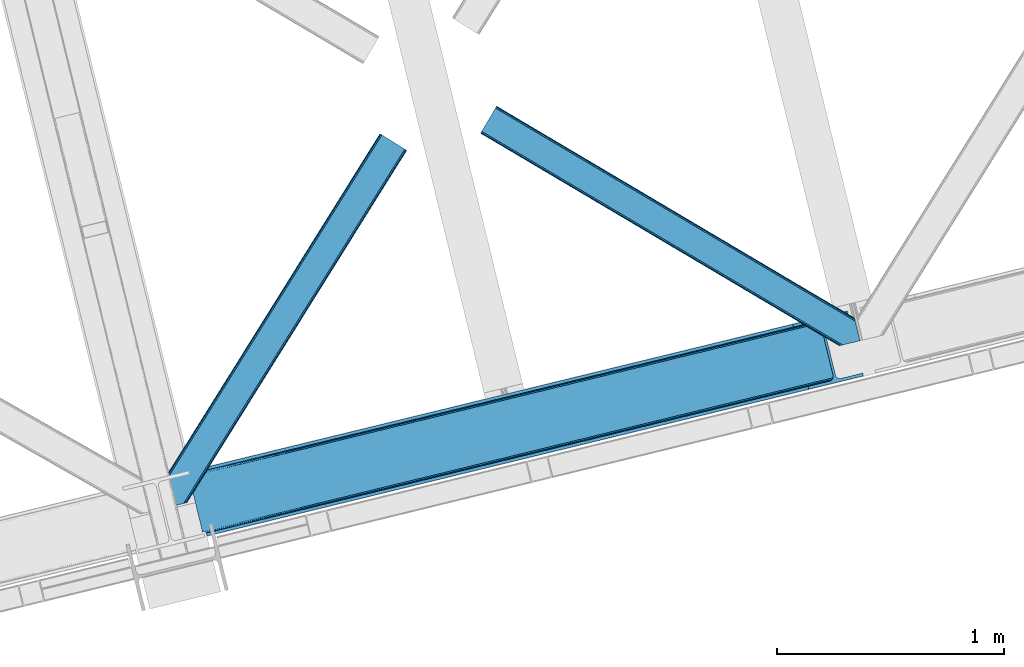
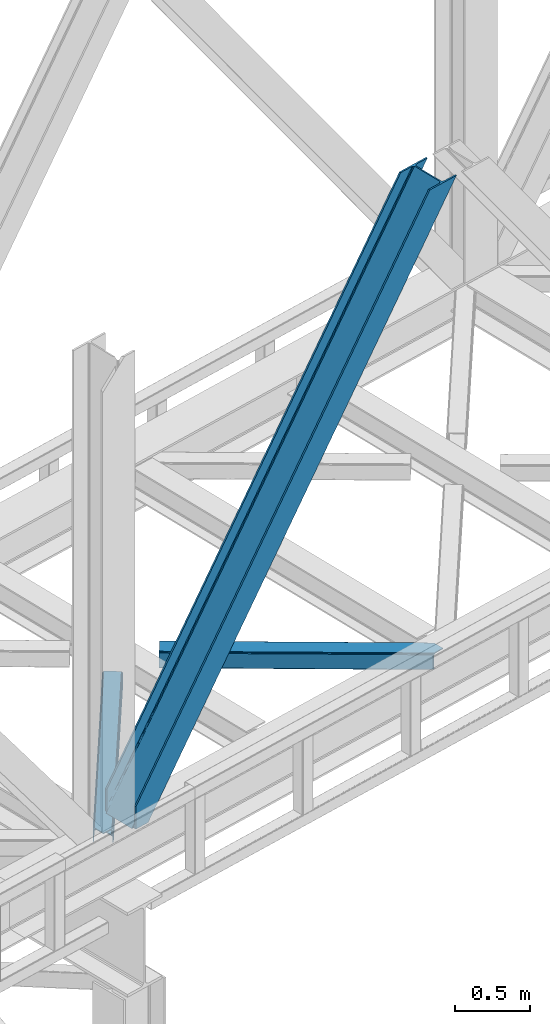
# One storey, part 58 of 92: 3 members.
"""IFC4 building model written with IfcOpenShell, lengths in millimetres."""

import ifcopenshell
import ifcopenshell.guid

model = None  # the IFC model being written
_history = None  # IfcOwnerHistory: only IFC2X3 demands one
_inside = {}  # id of a spatial element -> (the spatial element, [elements in it])
_under = {}  # id of a project, library or spatial element -> (it, [spatial elements below it])
_declared = {}  # id of a project -> (the project, [libraries it declares])
_typed = {}  # id of a type object -> (the type object, [elements of that type])
_made_of = {}  # id of a material, layer set ... -> (it, [elements and type objects made of it])


def new_model(schema):
    """Start an empty IFC model of exactly this schema.

    Asked for "IFC4X3", IfcOpenShell would pick the latest addendum, in which some entities
    have other attributes; the version numbers below select the first issue.
    IFC2X3 requires an IfcOwnerHistory on every rooted entity: one is made here for all.
    """
    global model, _history
    if schema == "IFC4X3":
        model = ifcopenshell.file(schema_version=(4, 3, 0, 0))
    else:
        model = ifcopenshell.file(schema=schema)
    _inside.clear()
    _under.clear()
    _declared.clear()
    _typed.clear()
    _made_of.clear()
    _history = None
    if model.schema == "IFC2X3":
        org = make("IfcOrganization", Name="unknown")
        user = make(
            "IfcPersonAndOrganization",
            ThePerson=make("IfcPerson", FamilyName="unknown"),
            TheOrganization=org,
        )
        app = make(
            "IfcApplication",
            ApplicationDeveloper=org,
            Version="unknown",
            ApplicationFullName="unknown",
            ApplicationIdentifier="unknown",
        )
        _history = make(
            "IfcOwnerHistory",
            OwningUser=user,
            OwningApplication=app,
            ChangeAction="ADDED",
            CreationDate=0,
        )
    return model


def make(cls, **values):
    """One entity of the class cls with the attributes given. An attribute that is None is left unset."""
    return model.create_entity(
        cls, **{name: value for name, value in values.items() if value is not None}
    )


def entity(cls, *values):
    """Any entity or typed value of the class cls, its attributes in the order of the schema. None: left unset."""
    e = model.create_entity(cls)
    for i, value in enumerate(values):
        if value is not None:
            e[i] = value
    return e


def rooted(cls, **values):
    """An entity with a GlobalId (a new one), such as an element, a storey or a relation."""
    return make(cls, GlobalId=ifcopenshell.guid.new(), OwnerHistory=_history, **values)


def si_unit(unit_type, name, prefix=None):
    """IfcSIUnit, for example si_unit("LENGTHUNIT", "METRE", prefix="MILLI")."""
    return make("IfcSIUnit", UnitType=unit_type, Prefix=prefix, Name=name)


def converted_unit(unit_type, name, factor, base, dimensions=None, offset=None):
    """IfcConversionBasedUnit, such as the inch: factor (a typed value) times the base unit."""
    return make(
        "IfcConversionBasedUnit"
        if offset is None
        else "IfcConversionBasedUnitWithOffset",
        ConversionOffset=offset,
        Dimensions=None
        if dimensions is None
        else entity("IfcDimensionalExponents", *dimensions),
        UnitType=unit_type,
        Name=name,
        ConversionFactor=make(
            "IfcMeasureWithUnit", ValueComponent=factor, UnitComponent=base
        ),
    )


def derived_unit(unit_type, elements):
    """IfcDerivedUnit: a product of units, each with its exponent."""
    return make(
        "IfcDerivedUnit",
        Elements=[
            make("IfcDerivedUnitElement", Unit=unit, Exponent=power)
            for unit, power in elements
        ],
        UnitType=unit_type,
    )


def assignment(units):
    """IfcUnitAssignment: the units of a project."""
    return None if units is None else make("IfcUnitAssignment", Units=units)


def point(xyz):
    """IfcCartesianPoint."""
    return None if xyz is None else make("IfcCartesianPoint", Coordinates=xyz)


def direction(xyz):
    """IfcDirection."""
    return None if xyz is None else make("IfcDirection", DirectionRatios=xyz)


def frame(location, z_axis=None, x_axis=None):
    """IfcAxis2Placement3D, a coordinate frame: its origin and axes. An axis left out is left unset."""
    return make(
        "IfcAxis2Placement3D",
        Location=point(location),
        Axis=direction(z_axis),
        RefDirection=direction(x_axis),
    )


def origin():
    """The frame at (0, 0, 0) with its axes left unset."""
    return frame((0.0, 0.0, 0.0))


def place(relative_to, where):
    """IfcLocalPlacement: puts the frame where relative to a parent placement (None: the world)."""
    return make(
        "IfcLocalPlacement", PlacementRelTo=relative_to, RelativePlacement=where
    )


def context(
    kind, dimensions, precision=None, world=None, true_north=None, identifier=None
):
    """IfcGeometricRepresentationContext, for example the 3D "Model" context."""
    return make(
        "IfcGeometricRepresentationContext",
        ContextIdentifier=identifier,
        ContextType=kind,
        CoordinateSpaceDimension=dimensions,
        Precision=precision,
        WorldCoordinateSystem=world,
        TrueNorth=true_north,
    )


def subcontext(parent, identifier, kind, view, scale=None):
    """IfcGeometricRepresentationSubContext, for example "Body" below "Model"."""
    return make(
        "IfcGeometricRepresentationSubContext",
        ContextIdentifier=identifier,
        ContextType=kind,
        ParentContext=parent,
        TargetScale=scale,
        TargetView=view,
    )


def project(units=None, contexts=None):
    """IfcProject with its units and contexts."""
    return rooted(
        "IfcProject",
        Name="project",
        RepresentationContexts=contexts,
        UnitsInContext=assignment(units),
    )


def spatial(cls, under=None, at=None, **own):
    """A site, building, storey or space (cls), placed at a placement, below another one or the project."""
    s = rooted(cls, ObjectPlacement=at, **own)
    if under is not None:
        _under.setdefault(under.id(), (under, []))[1].append(s)
    return s


def point_list(points):
    """IfcCartesianPointList2D or 3D."""
    cls = (
        "IfcCartesianPointList2D" if len(points[0]) == 2 else "IfcCartesianPointList3D"
    )
    return make(cls, CoordList=points)


def triangles(points, corners, closed=None, point_numbers=None):
    """IfcTriangulatedFaceSet: each triangle names its three corners, points numbered from 1."""
    return make(
        "IfcTriangulatedFaceSet",
        Coordinates=point_list(points),
        Closed=closed,
        CoordIndex=corners,
        PnIndex=point_numbers,
    )


def shape(context_of_items, identifier, shape_type, items):
    """IfcShapeRepresentation: the items that make up one representation, for example the "Body"."""
    return make(
        "IfcShapeRepresentation",
        ContextOfItems=context_of_items,
        RepresentationIdentifier=identifier,
        RepresentationType=shape_type,
        Items=items,
    )


def made_of(thing, what):
    """Note that an element or type object is made of a material, layer set ...; save() writes the relation."""
    if what is not None:
        _made_of.setdefault(what.id(), (what, []))[1].append(thing)
    return thing


def type_object(cls, material=None, **own):
    """A type object (cls), such as IfcWallType, which elements share."""
    return made_of(rooted(cls, **own), material)


def element(
    cls,
    number,
    at=None,
    inside=None,
    cuts=None,
    type_object=None,
    material=None,
    context=None,
    identifier="Body",
    shape_type=None,
    held_by="IfcProductDefinitionShape",
    body=None,
    shapes=None,
    **own,
):
    """One element of the class cls, such as IfcWall. Its Tag is "e" and its number.

    at: its placement. inside: the storey or other place that contains it. cuts: it is an
    opening in that element (IfcRelVoidsElement). A single representation is given by context,
    identifier, shape_type and body (its items); several are given by shapes. held_by: the class
    of the entity that holds the representations. save() writes the other relations.
    """
    e = rooted(cls, Tag="e%d" % number, ObjectPlacement=at, **own)
    if body is not None:
        shapes = [shape(context, identifier, shape_type, body)]
    if shapes is not None:
        e.Representation = make(held_by, Representations=shapes)
    if inside is not None:
        _inside.setdefault(inside.id(), (inside, []))[1].append(e)
    if cuts is not None:
        rooted(
            "IfcRelVoidsElement", RelatingBuildingElement=cuts, RelatedOpeningElement=e
        )
    if type_object is not None:
        _typed.setdefault(type_object.id(), (type_object, []))[1].append(e)
    return made_of(e, material)


def aggregate(whole, parts):
    """IfcRelAggregates: a whole, such as a stair, and the parts it consists of."""
    return rooted("IfcRelAggregates", RelatingObject=whole, RelatedObjects=parts)


def save(model, path):
    """Write the relations noted so far, then the file.

    IfcRelAggregates (storeys below a building ...), IfcRelContainedInSpatialStructure (elements
    in a storey), IfcRelDefinesByType, IfcRelAssociatesMaterial and IfcRelDeclares: one each for
    every whole, place, type object, material and project.
    """
    for whole, parts in _under.values():
        aggregate(whole, parts)
    for where, things in _inside.values():
        rooted(
            "IfcRelContainedInSpatialStructure",
            RelatedElements=things,
            RelatingStructure=where,
        )
    for kind, things in _typed.values():
        rooted("IfcRelDefinesByType", RelatedObjects=things, RelatingType=kind)
    for what, things in _made_of.values():
        rooted("IfcRelAssociatesMaterial", RelatedObjects=things, RelatingMaterial=what)
    for by, libraries in _declared.values():
        rooted("IfcRelDeclares", RelatingContext=by, RelatedDefinitions=libraries)
    model.write(path)


model = new_model("IFC4")

# Units and contexts
model_context = context("Model", 3, precision=0.01, world=origin(), true_north=direction((6.12303176911189e-17, 1.0)))
plan_context = context("Plan", 3, precision=0.01, world=origin(), true_north=direction((6.12303176911189e-17, 1.0)))
body_context = subcontext(model_context, "Body", "Model", "MODEL_VIEW")
ifc_project = project(units=[si_unit("LENGTHUNIT", "METRE", prefix="MILLI"), si_unit("AREAUNIT", "SQUARE_METRE"), si_unit("VOLUMEUNIT", "CUBIC_METRE"), converted_unit("PLANEANGLEUNIT", "DEGREE", entity("IfcRatioMeasure", 0.0174532925199433), si_unit("PLANEANGLEUNIT", "RADIAN"), dimensions=[0, 0, 0, 0, 0, 0, 0]), si_unit("MASSUNIT", "GRAM", prefix="KILO"), derived_unit("MASSDENSITYUNIT", [(si_unit("MASSUNIT", "GRAM", prefix="KILO"), 1), (si_unit("LENGTHUNIT", "METRE"), -3)]), derived_unit("MOMENTOFINERTIAUNIT", [(si_unit("LENGTHUNIT", "METRE"), 4)]), si_unit("TIMEUNIT", "SECOND"), si_unit("FREQUENCYUNIT", "HERTZ"), si_unit("THERMODYNAMICTEMPERATUREUNIT", "DEGREE_CELSIUS"), derived_unit("THERMALTRANSMITTANCEUNIT", [(si_unit("MASSUNIT", "GRAM", prefix="KILO"), 1), (si_unit("THERMODYNAMICTEMPERATUREUNIT", "KELVIN"), -1), (si_unit("TIMEUNIT", "SECOND"), -3)]), derived_unit("VOLUMETRICFLOWRATEUNIT", [(si_unit("LENGTHUNIT", "METRE"), 3), (si_unit("TIMEUNIT", "SECOND"), -1)]), derived_unit("MASSFLOWRATEUNIT", [(si_unit("MASSUNIT", "GRAM", prefix="KILO"), 1), (si_unit("TIMEUNIT", "SECOND"), -1)]), derived_unit("ROTATIONALFREQUENCYUNIT", [(si_unit("TIMEUNIT", "SECOND"), -1)]), si_unit("ELECTRICCURRENTUNIT", "AMPERE"), si_unit("ELECTRICVOLTAGEUNIT", "VOLT"), si_unit("POWERUNIT", "WATT"), si_unit("FORCEUNIT", "NEWTON", prefix="KILO"), si_unit("ILLUMINANCEUNIT", "LUX"), si_unit("LUMINOUSFLUXUNIT", "LUMEN"), si_unit("LUMINOUSINTENSITYUNIT", "CANDELA"), derived_unit("USERDEFINED", [(si_unit("MASSUNIT", "GRAM", prefix="KILO"), -1), (si_unit("LENGTHUNIT", "METRE"), -2), (si_unit("TIMEUNIT", "SECOND"), 3), (si_unit("LUMINOUSFLUXUNIT", "LUMEN"), 1)]), derived_unit("LINEARVELOCITYUNIT", [(si_unit("LENGTHUNIT", "METRE"), 1), (si_unit("TIMEUNIT", "SECOND"), -1)]), si_unit("PRESSUREUNIT", "PASCAL"), derived_unit("USERDEFINED", [(si_unit("LENGTHUNIT", "METRE"), -2), (si_unit("MASSUNIT", "GRAM", prefix="KILO"), 1), (si_unit("TIMEUNIT", "SECOND"), -2)]), derived_unit("LINEARFORCEUNIT", [(si_unit("MASSUNIT", "GRAM", prefix="KILO"), 1), (si_unit("LENGTHUNIT", "METRE"), 1), (si_unit("TIMEUNIT", "SECOND"), -2), (si_unit("LENGTHUNIT", "METRE"), -1)]), derived_unit("PLANARFORCEUNIT", [(si_unit("MASSUNIT", "GRAM", prefix="KILO"), 1), (si_unit("LENGTHUNIT", "METRE"), 1), (si_unit("TIMEUNIT", "SECOND"), -2), (si_unit("LENGTHUNIT", "METRE"), -2)])], contexts=[model_context, plan_context])

# Site, building, storey
site_placement = place(None, origin())
site = spatial("IfcSite", under=ifc_project, at=site_placement, CompositionType="ELEMENT")
building_placement = place(site_placement, origin())
building = spatial("IfcBuilding", under=site, at=building_placement, CompositionType="ELEMENT")
storey_placement = place(building_placement, frame((0.0, 0.0, 15900.0)))
storey = spatial("IfcBuildingStorey", under=building, at=storey_placement, Name="05", CompositionType="ELEMENT", Elevation=15900.0)

# Members
member_type_1 = type_object("IfcMemberType", PredefinedType="BRACE")
member_1_placement = place(storey_placement, frame((-29318.71, 10322.57, 3695.0)))
element("IfcMember", 1, at=member_1_placement, inside=storey, type_object=member_type_1, ObjectType="Steel Vertical Brace", PredefinedType="BRACE", context=body_context, shape_type="Tessellation", body=[
    triangles([(58.549914550782, 26.6251190185558, 0.0), (60.4428222656279, 18.8523376464855, 0.0), (59.105694580081, 19.6708923339847, 0.80925292968459), (58.9708190917991, 18.4930572509766, 1.10690917968532), (64.0867858886741, 19.7406555175785, 8.31577148437282), (64.0867858886741, 19.7406555175785, 0.0), (522.907617187502, 126.716683959961, 658.855133056641), (68.3748962402351, 19.9243652343757, 14.8293273925774), (72.407208251956, 18.4523620605469, 22.4381652832017), (524.584259033203, 133.136059570314, 656.552947998047), (73.9861816406265, 17.2873168945316, 26.4425720214822), (2834.75720214844, 696.264477539064, 3911.00081176758), (2834.77580566406, 703.359393310548, 3911.00081176758), (2385.95203857422, 593.954443359375, 3278.7231262207), (2386.50781860352, 586.999053955078, 3279.53005371094), (2831.44577636719, 689.447451782227, 3911.00081176758), (2384.82885131836, 580.579678344728, 3281.83223876953), (2825.34149780274, 683.943136596679, 3911.00081176758), (2381.1709350586, 575.671838378907, 3285.27854003906), (2817.37686767578, 680.591015625001, 3911.00081176758), (2376.09450073242, 573.024325561524, 3289.34108276367), (514.170941162112, 119.160168457032, 666.36397705078), (519.249700927736, 121.80884399414, 662.301434326171), (77.0999450683594, 12.6201599121105, 50.6410949707024), (76.5674194335952, 13.9003143310547, 38.6743835449197), (75.4046997070327, 15.4258026123043, 33.1630920410134), (524.028479003908, 140.090286254883, 655.74602050781), (990.065148925783, 246.602389526368, 1312.29896850586), (989.509368896484, 253.556616210937, 1311.48971557617), (1455.54603881836, 360.067556762695, 1968.04266357422), (1454.99025878906, 367.021783447266, 1967.23341064453), (1921.02692871094, 473.533886718751, 2623.78635864258), (1920.47114868164, 480.48811340332, 2622.97710571289), (988.388507080079, 240.18185119629, 1314.598828125), (1453.8670715332, 353.648181152344, 1970.34484863281), (1919.34796142578, 467.113348388672, 2626.08854370117), (984.730590820313, 235.274011230469, 1318.04512939453), (1450.21148071289, 348.740341186523, 1973.78882446289), (1915.69004516602, 462.205508422852, 2629.53251953125), (979.651831054689, 232.626498413087, 1322.10767211914), (1445.13272094727, 346.092828369141, 1977.85369262695), (1910.61361083985, 459.55799560547, 2633.59738769531), (77.0999450683594, 12.6201599121105, 182.433050537107), (2723.82443847656, 657.78659362793, 3911.00081176758), (75.569805908206, 15.550213623048, 0.0), (77.381323242189, 11.6585906982418, 0.0), (77.381323242189, 11.6585906982418, 182.495837402341), (68.3748962402351, 19.9243652343757, 0.0), (72.407208251956, 18.4523620605469, 0.0), (2726.9033203125, 645.157131958009, 3911.00081176758), (80.223010253907, 0.0, 182.495837402341), (80.223010253907, 0.0, 0.0), (191.327856445314, 27.0832305908207, 0.0), (2967.5537475586, 703.817504882813, 3911.00081176758), (1399.80990600586, 593.394012451172, 1967.23341064453), (2779.59312744141, 929.730459594726, 3911.00081176758), (2330.77168579102, 820.325509643555, 3278.7231262207), (1865.29079589844, 706.859179687501, 2622.97710571289), (934.329016113283, 479.927682495118, 1311.48971557617), (468.848126220706, 366.462515258789, 655.74602050781), (3.36723632812573, 252.996185302734, 0.0), (2964.47486572266, 716.448129272461, 3911.00081176758), (188.248974609378, 39.7138549804695, 0.0), (2870.92243652344, 693.643707275391, 3911.00081176758), (94.6965454101592, 16.9094329833988, 0.0), (2862.31133422852, 692.954214477539, 3911.00081176758), (86.083117675782, 16.2199401855469, 0.0), (2854.35833129883, 695.031994628907, 3911.00081176758), (78.1324401855491, 18.2977203369137, 0.0), (2848.28195800781, 699.561950683594, 3911.00081176758), (72.0560668945327, 22.8265136718746, 0.0), (2845.00308837891, 705.852264404297, 3911.00081176758), (68.7748718261719, 29.1168273925778, 0.0), (2789.82273559571, 932.224493408203, 3911.00081176758), (13.5945190429702, 255.489056396485, 0.0), (2789.83668823242, 939.318246459961, 3911.00081176758), (13.6107971191414, 262.583972167969, 0.0), (2793.15043945313, 946.135272216798, 3911.00081176758), (16.9245483398445, 269.400997924806, 0.0), (2799.25471801758, 951.639587402344, 3911.00081176758), (23.026501464843, 274.905313110352, 0.0), (2807.21702270508, 954.991708374024, 3911.00081176758), (30.9911315917961, 278.256271362305, 0.0), (2900.7694519043, 977.796130371094, 3911.00081176758), (124.543560791019, 301.060693359375, 0.0), (2897.69057006836, 990.425592041016, 3911.00081176758), (121.464678955079, 313.691317749024, 0.0), (2770.23555908203, 940.550729370118, 3911.00081176758), (2762.2848815918, 942.628509521484, 3911.00081176758), (2657.04014282227, 931.765219116211, 3911.00081176758), (2753.67145385742, 941.939016723632, 3911.00081176758), (2660.1190246582, 919.134594726564, 3911.00081176758), (2776.3142578125, 936.020773315429, 3911.00081176758), (10.3598327636719, 286.608087158203, 182.495837402341), (10.3598327636719, 286.608087158203, 0.0), (13.2015197753899, 274.949496459962, 182.495837402341), (13.3922058105491, 273.966998291016, 182.433050537107), (1381.42730712891, 607.439666748047, 1977.85369262695), (1846.90819702149, 720.905996704101, 2633.59738769531), (2312.38676147461, 834.37116394043, 3289.34108276367), (915.94641723633, 493.97449951172, 1322.10767211914), (13.3922058105491, 273.966998291016, 50.6410949707024), (450.465527343753, 380.508169555664, 666.36397705078), (13.2015197753899, 274.949496459962, 0.0), (13.5108032226563, 272.58568725586, 38.6743835449197), (13.3829040527344, 270.661386108399, 0.0), (13.3829040527344, 270.661386108399, 32.1678039550752), (12.4783081054702, 268.183630371093, 26.1867736816384), (11.9132263183601, 266.62907409668, 22.4381652832017), (11.9132263183601, 266.62907409668, 0.0), (9.00875244140843, 263.467639160157, 14.8293273925774), (9.00875244140843, 263.467639160157, 0.0), (5.11829223632958, 261.6572845459, 8.31577148437282), (5.11829223632958, 261.6572845459, 0.0), (1.47432861328343, 260.768966674805, 0.0), (461.697399902347, 377.819961547852, 658.855133056641), (456.193084716797, 380.494216918945, 662.301434326171), (466.141314697266, 372.892355346679, 656.552947998047), (0.662750244140625, 259.427188110352, 0.80925292968459), (0.0, 260.409686279298, 1.10690917968532), (2318.11431884766, 834.357211303712, 3285.27854003906), (2323.62095947266, 831.682955932618, 3281.83223876953), (2328.06487426758, 826.755349731446, 3279.53005371094), (921.671649169923, 493.959384155274, 1318.04512939453), (1387.1525390625, 607.425714111328, 1973.78882446289), (1852.63342895508, 720.890881347657, 2629.53251953125), (927.178289794923, 491.28512878418, 1314.598828125), (1392.6591796875, 604.751458740235, 1970.34484863281), (1858.14006958008, 718.216625976564, 2626.08854370117), (931.622204589847, 486.358685302735, 1312.29896850586), (1397.10309448242, 599.823852539063, 1968.04266357422), (1862.583984375, 713.290182495117, 2623.78635864258)], [[1, 2, 3], [4, 3, 2], [5, 4, 6], [2, 6, 4], [7, 8, 9], [10, 3, 8], [8, 7, 10], [9, 11, 7], [3, 4, 5], [5, 8, 3], [12, 13, 14], [14, 15, 12], [16, 12, 15], [15, 17, 16], [18, 16, 17], [17, 19, 18], [20, 18, 19], [19, 21, 20], [22, 23, 24], [25, 24, 23], [25, 7, 26], [25, 23, 7], [11, 26, 7], [10, 27, 1], [1, 3, 10], [28, 29, 27], [27, 10, 28], [30, 31, 28], [29, 28, 31], [32, 33, 31], [31, 30, 32], [15, 14, 33], [33, 32, 15], [34, 28, 10], [10, 7, 34], [35, 30, 28], [28, 34, 35], [36, 32, 35], [30, 35, 32], [17, 15, 36], [32, 36, 15], [37, 34, 23], [7, 23, 34], [38, 35, 37], [34, 37, 35], [39, 36, 38], [35, 38, 36], [19, 17, 36], [36, 39, 19], [40, 37, 22], [23, 22, 37], [41, 38, 40], [37, 40, 38], [42, 39, 41], [38, 41, 39], [21, 19, 42], [39, 42, 19], [41, 43, 44], [44, 21, 42], [21, 44, 20], [42, 41, 44], [43, 41, 40], [40, 22, 43], [24, 43, 22], [45, 11, 9], [45, 26, 11], [46, 25, 26], [46, 47, 24], [43, 24, 47], [24, 25, 46], [26, 45, 46], [48, 8, 5], [5, 6, 48], [49, 9, 8], [8, 48, 49], [9, 49, 45], [47, 44, 43], [50, 47, 51], [47, 50, 44], [52, 51, 46], [47, 46, 51], [50, 53, 54], [53, 50, 51], [52, 53, 51], [33, 55, 31], [13, 56, 57], [58, 14, 57], [55, 33, 58], [57, 14, 13], [58, 33, 14], [31, 59, 29], [59, 60, 27], [59, 31, 55], [61, 1, 60], [59, 27, 29], [60, 1, 27], [62, 54, 53], [53, 63, 62], [64, 62, 63], [63, 65, 64], [66, 64, 65], [65, 67, 66], [68, 66, 67], [67, 69, 68], [70, 68, 69], [69, 71, 70], [72, 70, 71], [71, 73, 72], [74, 72, 75], [73, 75, 72], [76, 74, 77], [75, 77, 74], [78, 76, 79], [77, 79, 76], [80, 78, 81], [79, 81, 78], [82, 80, 83], [81, 83, 80], [84, 82, 85], [83, 85, 82], [86, 84, 85], [85, 87, 86], [56, 13, 74], [16, 18, 66], [20, 50, 54], [44, 50, 20], [18, 20, 64], [13, 12, 70], [12, 16, 68], [88, 80, 89], [90, 91, 86], [91, 89, 82], [90, 92, 91], [88, 93, 78], [93, 56, 76], [74, 13, 72], [64, 66, 18], [70, 12, 68], [66, 68, 16], [70, 72, 13], [54, 64, 20], [54, 62, 64], [82, 89, 80], [78, 93, 76], [74, 76, 56], [78, 80, 88], [82, 86, 91], [86, 82, 84], [90, 87, 94], [90, 86, 87], [87, 95, 94], [96, 90, 94], [92, 96, 97], [96, 92, 90], [92, 97, 98], [98, 99, 92], [99, 100, 92], [91, 92, 100], [101, 98, 97], [97, 102, 103], [103, 101, 97], [104, 96, 94], [94, 95, 104], [104, 105, 102], [104, 106, 107], [107, 105, 104], [96, 104, 102], [102, 97, 96], [108, 106, 109], [108, 107, 106], [110, 109, 106], [109, 110, 111], [112, 111, 110], [111, 112, 113], [114, 113, 112], [75, 73, 61], [114, 75, 61], [114, 112, 75], [114, 61, 115], [79, 77, 110], [77, 75, 112], [106, 79, 110], [110, 77, 112], [73, 1, 61], [6, 73, 48], [1, 6, 2], [1, 73, 6], [48, 71, 49], [49, 71, 69], [73, 71, 48], [45, 49, 69], [104, 81, 79], [79, 106, 104], [95, 81, 104], [83, 95, 87], [87, 85, 83], [83, 81, 95], [45, 69, 46], [52, 67, 65], [46, 69, 67], [52, 46, 67], [65, 53, 52], [53, 65, 63], [116, 117, 105], [105, 107, 116], [118, 111, 113], [113, 119, 118], [118, 116, 108], [108, 109, 118], [109, 111, 118], [113, 120, 119], [107, 108, 116], [117, 103, 102], [102, 105, 117], [89, 91, 121], [100, 121, 91], [88, 89, 122], [121, 122, 89], [93, 88, 123], [122, 123, 88], [56, 93, 57], [123, 57, 93], [124, 101, 103], [103, 117, 124], [125, 98, 101], [101, 124, 125], [126, 99, 98], [98, 125, 126], [121, 100, 126], [99, 126, 100], [127, 124, 116], [117, 116, 124], [128, 125, 124], [124, 127, 128], [129, 126, 128], [125, 128, 126], [122, 121, 129], [126, 129, 121], [130, 127, 118], [116, 118, 127], [131, 128, 130], [127, 130, 128], [132, 129, 128], [128, 131, 132], [123, 122, 129], [129, 132, 123], [60, 118, 61], [119, 61, 118], [59, 130, 60], [118, 60, 130], [55, 131, 130], [130, 59, 55], [58, 132, 55], [131, 55, 132], [57, 123, 58], [132, 58, 123], [120, 113, 114], [114, 115, 120], [115, 61, 119], [119, 120, 115]]),
])
member_type_2 = type_object("IfcMemberType", PredefinedType="BRACE")
member_2_placement = place(storey_placement, frame((-29442.53, 10446.83, 3510.0)))
element("IfcMember", 2, at=member_2_placement, inside=storey, type_object=member_type_2, ObjectType="Steel Horizontal Brace", PredefinedType="BRACE", context=body_context, shape_type="Tessellation", body=[
    triangles([(116.813800048829, 229.38483581543, 5.52059326172093), (80.4834594726563, 220.529562377929, 5.52059326172093), (108.163165283204, 264.867553710938, 5.52059326172093), (117.183544921878, 229.4755279541, 5.44385375976708), (117.499804687501, 229.552267456054, 5.22758789062573), (108.467797851565, 265.047775268555, 5.35316162109666), (108.779406738282, 265.232647705077, 5.18107910156323), (109.021252441409, 265.045449829102, 4.88574829101708), (108.879400634767, 265.291946411133, 5.12526855468968), (117.709094238282, 229.603427124022, 4.90318908691552), (109.242169189456, 264.669891357422, 4.52065429687718), (117.783508300781, 229.622030639648, 4.52065429687718), (113.127978515626, 248.727841186523, 0.0), (110.909509277346, 257.823797607422, 1.33247680664135), (117.783508300781, 229.622030639648, 0.0), (973.808001708985, 1640.09989013672, 1.33247680664135), (968.992016601565, 1643.10668334961, 5.12526855468968), (965.773608398438, 1645.11586303711, 10.8028289794929), (75.7418884277358, 219.37265625, 10.8028289794929), (979.48905029297, 1636.5535949707, 0.0), (964.645770263673, 1645.82047119141, 17.5000946044929), (73.8885131835959, 218.921520996093, 17.5000946044929), (127.499194335938, 231.98932800293, 0.0), (1068.55803222656, 1580.95117492676, 0.0), (155.288195800782, 117.985821533202, 0.0), (1074.23908081055, 1577.40487976074, 1.33247680664135), (157.506665039065, 108.891027832031, 1.33247680664135), (1079.05506591797, 1574.39808654785, 5.12526855468968), (159.385620117188, 101.179870605469, 5.12526855468968), (1082.2734741211, 1572.39006958008, 10.8028289794929), (160.641357421875, 96.0278594970696, 10.8028289794929), (1083.40363769532, 1571.68429870605, 17.5000946044929), (161.083190917969, 94.2186676025394, 17.5000946044929), (127.499194335938, 231.98932800293, 6.99957275390625), (107.953875732423, 227.225665283202, 6.99957275390625), (98.6428161621116, 224.956036376952, 8.3320495605476), (86.1482299804702, 221.909710693359, 18.0686645507813), (90.7502746582031, 223.031735229491, 12.1260040283232), (84.264624023439, 221.450436401366, 20.4999114990242), (73.8885131835959, 218.921520996093, 20.4999114990242), (985.425897216799, 1632.84684448242, 6.99957275390625), (1062.62118530274, 1584.65792541504, 6.99957275390625), (152.972058105472, 127.492218017578, 6.99957275390625), (157.067156982423, 110.68742980957, 12.1260040283232), (155.188201904297, 118.397424316407, 8.3320495605476), (158.222900390625, 105.947021484375, 17.9802978515654), (158.52288208008, 104.716864013672, 19.4999725341804), (161.083190917969, 94.2186676025394, 19.4999725341804), (157.871759033205, 103.169284057616, 20.4999114990242), (160.341375732423, 93.0338562011711, 20.4999114990242), (116.220812988282, 22.3544494628895, 20.4999114990242), (105.842376708984, 19.8255340576161, 20.4999114990242), (1083.40363769532, 1571.68429870605, 122.500662231447), (116.220812988282, 22.3544494628895, 122.500662231447), (1076.33662719727, 1576.09682006836, 17.8035644531265), (1073.11821899414, 1578.10483703613, 12.1260040283232), (1077.46446533203, 1575.39104919434, 24.4996673583992), (106.486523437503, 19.982501220702, 24.4996673583992), (1068.30223388672, 1581.11163024902, 8.3320495605476), (1082.2734741211, 1572.39006958008, 129.197927856447), (114.367437744142, 21.9033142089847, 129.197927856447), (1079.05506591797, 1574.39808654785, 134.874325561526), (109.093341064454, 20.6173461914059, 134.874325561526), (1074.23908081055, 1577.40487976074, 138.667117309571), (101.198474121094, 18.6930450439449, 138.667117309571), (1068.55803222656, 1580.95117492676, 139.999594116212), (91.8874145507834, 16.4234161376953, 139.999594116212), (1077.46446533203, 1575.39104919434, 115.501089477541), (106.486523437503, 19.982501220702, 115.501089477541), (1062.62118530274, 1584.65792541504, 133.000021362306), (1068.30223388672, 1581.11163024902, 131.667544555665), (91.4641845703154, 16.3199340820302, 131.667544555665), (82.1554504394553, 14.0503051757805, 133.000021362306), (1073.11821899414, 1578.10483703613, 127.87475280762), (99.3613769531257, 18.2453979492184, 127.87475280762), (1076.33662719727, 1576.09682006836, 122.196029663086), (104.635473632814, 19.5302032470699, 122.196029663086), (24.5101318359375, 0.0, 139.999594116212), (24.5101318359375, 0.0, 133.000021362306), (2.46961669922166, 90.4212249755856, 20.4999114990242), (0.0, 100.556652832031, 20.4999114990242), (964.645770263673, 1645.82047119141, 122.500662231447), (0.0, 100.556652832031, 122.500662231447), (5.79266967773583, 76.7894989013676, 139.999594116212), (979.48905029297, 1636.5535949707, 139.999594116212), (973.808001708985, 1640.09989013672, 138.667117309571), (3.57652587890698, 85.8854553222645, 138.667117309571), (968.992016601565, 1643.10668334961, 134.874325561526), (1.69524536133031, 93.5954498291012, 134.874325561526), (965.773608398438, 1645.11586303711, 129.197927856447), (0.439508056642808, 98.7474609375004, 129.197927856447), (970.582617187501, 1642.11372070312, 24.4996673583992), (2.31613769531396, 91.0502563476566, 24.4996673583992), (971.710455322267, 1641.4079498291, 17.8035644531265), (979.744848632814, 1636.39313964844, 8.3320495605476), (974.928863525394, 1639.39993286133, 12.1260040283232), (974.928863525394, 1639.39993286133, 127.87475280762), (985.425897216799, 1632.84684448242, 133.000021362306), (979.744848632814, 1636.39313964844, 131.667544555665), (970.582617187501, 1642.11372070312, 115.501089477541), (971.710455322267, 1641.4079498291, 122.196029663086), (4.01370849609521, 84.0890533447255, 127.87475280762), (2.75797119140771, 89.2410644531246, 122.196029663086), (8.10880737304979, 67.2831024169918, 133.000021362306), (5.89266357422093, 76.3790588378906, 131.667544555665), (2.31613769531396, 91.0502563476566, 115.501089477541)], [[1, 2, 3], [4, 1, 3], [5, 4, 6], [5, 7, 8], [7, 9, 8], [10, 8, 11], [11, 12, 10], [8, 10, 5], [6, 7, 5], [3, 6, 4], [11, 13, 12], [13, 11, 14], [15, 12, 13], [16, 14, 11], [11, 17, 16], [11, 9, 17], [18, 17, 9], [18, 3, 19], [2, 19, 3], [16, 20, 14], [13, 14, 20], [21, 18, 19], [19, 22, 21], [23, 24, 25], [24, 13, 20], [13, 24, 23], [23, 15, 13], [24, 26, 25], [27, 25, 26], [26, 28, 27], [29, 27, 28], [28, 30, 29], [31, 29, 30], [30, 32, 31], [33, 31, 32], [15, 23, 10], [10, 34, 1], [34, 10, 23], [35, 1, 34], [36, 2, 35], [35, 2, 1], [2, 37, 19], [38, 37, 2], [2, 36, 38], [37, 39, 19], [39, 22, 19], [39, 40, 22], [34, 41, 35], [42, 34, 43], [34, 42, 41], [44, 27, 29], [34, 23, 43], [23, 25, 43], [27, 45, 25], [44, 45, 27], [45, 43, 25], [46, 44, 29], [31, 46, 29], [47, 31, 33], [31, 47, 46], [33, 48, 47], [49, 50, 51], [51, 52, 49], [53, 48, 32], [48, 53, 54], [33, 32, 48], [54, 50, 48], [54, 51, 50], [55, 56, 44], [57, 55, 46], [46, 47, 57], [47, 49, 57], [57, 49, 58], [52, 58, 49], [44, 46, 55], [56, 59, 45], [45, 44, 56], [59, 42, 43], [43, 45, 59], [53, 60, 54], [61, 54, 60], [60, 62, 61], [63, 61, 62], [62, 64, 63], [65, 63, 64], [64, 66, 65], [67, 65, 66], [68, 57, 69], [58, 69, 57], [70, 71, 72], [72, 73, 70], [71, 74, 75], [75, 72, 71], [74, 76, 77], [77, 75, 74], [76, 68, 69], [69, 77, 76], [77, 61, 63], [73, 67, 78], [78, 79, 73], [73, 72, 67], [72, 65, 67], [75, 65, 72], [63, 65, 75], [77, 54, 61], [69, 54, 77], [63, 75, 77], [51, 58, 52], [69, 51, 54], [58, 51, 69], [40, 39, 80], [80, 81, 40], [40, 21, 22], [82, 40, 83], [40, 82, 21], [40, 81, 83], [66, 84, 67], [66, 85, 84], [84, 78, 67], [85, 86, 87], [87, 84, 85], [86, 88, 89], [89, 87, 86], [88, 90, 91], [91, 89, 88], [90, 82, 83], [83, 91, 90], [92, 93, 39], [39, 94, 92], [39, 37, 94], [93, 80, 39], [94, 37, 38], [41, 95, 35], [36, 35, 95], [95, 96, 36], [38, 36, 96], [38, 96, 94], [30, 56, 55], [57, 53, 32], [30, 55, 32], [30, 28, 56], [55, 57, 32], [56, 28, 26], [42, 24, 20], [24, 59, 26], [59, 24, 42], [59, 56, 26], [60, 74, 62], [68, 53, 57], [53, 76, 60], [76, 53, 68], [60, 76, 74], [66, 70, 85], [64, 62, 74], [74, 71, 64], [71, 70, 66], [66, 64, 71], [96, 16, 17], [20, 41, 42], [20, 95, 41], [95, 20, 16], [96, 95, 16], [92, 21, 82], [18, 94, 96], [17, 18, 96], [94, 18, 21], [92, 94, 21], [86, 97, 88], [85, 70, 98], [98, 99, 85], [99, 97, 86], [86, 85, 99], [90, 88, 97], [82, 100, 92], [101, 82, 90], [82, 101, 100], [101, 90, 97], [102, 89, 103], [79, 78, 104], [78, 84, 104], [87, 105, 84], [102, 105, 87], [105, 104, 84], [102, 87, 89], [83, 81, 106], [91, 103, 89], [106, 103, 83], [103, 91, 83], [81, 93, 106], [81, 80, 93], [70, 104, 98], [104, 70, 73], [79, 104, 73], [92, 100, 93], [106, 93, 100], [100, 101, 106], [103, 106, 101], [101, 97, 103], [102, 103, 97], [97, 99, 102], [105, 102, 99], [99, 98, 105], [104, 105, 98]]),
])
member_type_3 = type_object("IfcMemberType", PredefinedType="BRACE")
member_3_placement = place(storey_placement, frame((-28035.7, 11159.18, 3510.0)))
element("IfcMember", 3, at=member_3_placement, inside=storey, type_object=member_type_3, ObjectType="Steel Horizontal Brace", PredefinedType="BRACE", context=body_context, shape_type="Tessellation", body=[
    triangles([(1465.49891967774, 208.966314697265, 0.0), (1500.25958862305, 66.3657165527347, 0.0), (8.91573486328343, 949.276940917969, 0.0), (62.405493164064, 1039.62956542969, 0.0), (0.679028320311772, 935.364999389649, 10.8028289794929), (1580.23377685547, 0.541827392578853, 10.8679412841811), (1578.00833129883, 0.0, 17.5000946044929), (1506.61734008789, 44.5019348144524, 9.52034912109593), (2.6114685058601, 938.628753662109, 5.12526855468968), (1504.3546875, 49.5597656249993, 5.12526855468968), (1505.23137817383, 45.9657989501957, 8.52041015625218), (1506.28247680664, 44.8554016113285, 9.27850341796875), (1505.92435913086, 45.2344482421868, 9.02037963867406), (1505.56624145508, 45.6123321533196, 8.76225585937573), (1580.68491210938, 0.65228576660229, 9.52034912109593), (1502.47573242188, 57.2709228515632, 1.33247680664135), (5.50431518554615, 943.514501953125, 1.33247680664135), (0.0, 934.218557739257, 17.5000946044929), (1578.00833129883, 0.0, 122.500662231447), (0.0, 934.218557739257, 122.500662231447), (1593.02834472656, 3.66140441894458, 138.667117309571), (1602.33940429688, 5.93103332519604, 139.999594116212), (8.91573486328343, 949.276940917969, 139.999594116212), (5.50431518554615, 943.514501953125, 138.667117309571), (1585.13347778321, 1.73710327148365, 134.874325561526), (2.6114685058601, 938.628753662109, 134.874325561526), (1579.85938110352, 0.451135253906614, 129.197927856447), (0.679028320311772, 935.364999389649, 129.197927856447), (1500.30377197266, 66.1831695556648, 8.52041015625218), (1500.66188964844, 65.0402160644535, 8.90294494629052), (1501.15255737305, 64.3216552734375, 9.10758361816625), (1501.64787597656, 63.5914672851559, 9.31571044922021), (1502.13854370117, 62.8729064941399, 9.52034912109593), (1599.49306640625, 5.23688964843677, 9.52034912109593), (9.07153930664208, 949.538552856446, 8.3320495605476), (1500.15029296875, 66.8075500488285, 8.42274169922166), (6.1786926269524, 944.65280456543, 12.1260040283232), (1594.86776733398, 4.11021423339844, 12.1260040283232), (1497.94112548828, 75.8721130371086, 6.99957275390625), (12.4829589843757, 955.300991821288, 6.99957275390625), (1589.5936706543, 2.82424621581958, 17.8035644531265), (4.24625244140771, 941.387887573243, 17.8035644531265), (1587.74029541016, 2.3719482421875, 24.4996673583992), (3.56489868164135, 940.241445922851, 24.4996673583992), (1467.81505737305, 199.458755493164, 6.99957275390625), (58.8405944824226, 1033.60667724609, 6.99957275390625), (1460.52713012695, 229.365069580079, 8.52041015625218), (1465.45473632813, 209.14769897461, 8.52041015625218), (1461.40149536133, 225.771102905273, 5.12526855468968), (1465.60588989258, 208.524481201172, 8.42274169922166), (1463.28045043946, 218.061108398437, 1.33247680664135), (1587.74029541016, 2.3719482421875, 115.501089477541), (3.56489868164135, 940.241445922851, 115.501089477541), (1589.5936706543, 2.82424621581958, 122.196029663086), (4.24625244140771, 941.387887573243, 122.196029663086), (1594.86776733398, 4.11021423339844, 127.87475280762), (6.1786926269524, 944.65280456543, 127.87475280762), (1602.76263427734, 6.03451538085938, 131.667544555665), (9.07153930664208, 949.538552856446, 131.667544555665), (1612.07369384766, 8.30414428710901, 133.000021362306), (12.4829589843757, 955.300991821288, 133.000021362306), (1669.50739746094, 22.3044525146488, 139.999594116212), (1669.50739746094, 22.3044525146488, 133.000021362306), (1650.74110107422, 99.2974273681648, 139.999594116212), (62.405493164064, 1039.62956542969, 139.999594116212), (1653.05723876953, 89.7910308837891, 133.000021362306), (58.8405944824226, 1033.60667724609, 133.000021362306), (1645.38793945313, 121.255389404298, 129.197927856447), (1644.94610595703, 123.064581298828, 122.500662231447), (70.642199707032, 1053.54266967773, 129.197927856447), (71.3235534667983, 1054.68911132813, 122.500662231447), (1646.64367675781, 116.103378295898, 134.874325561526), (68.7120849609382, 1050.27891540527, 134.874325561526), (1648.52263183594, 108.393383789062, 138.667117309571), (65.8192382812522, 1045.39316711426, 138.667117309571), (1644.94610595703, 123.064581298828, 17.5000946044929), (71.3235534667983, 1054.68911132813, 17.5000946044929), (70.642199707032, 1053.54266967773, 10.8028289794929), (65.1448608398459, 1044.25486450195, 12.1260040283232), (67.0773010253906, 1047.51978149414, 17.8035644531265), (67.7563293457024, 1048.6650604248, 24.4996673583992), (68.7120849609382, 1050.27891540527, 5.12526855468968), (65.8192382812522, 1045.39316711426, 1.33247680664135), (62.2520141601563, 1039.36911621094, 8.3320495605476), (65.1448608398459, 1044.25486450195, 127.87475280762), (67.7563293457024, 1048.6650604248, 115.501089477541), (67.0773010253906, 1047.51978149414, 122.196029663086), (62.2520141601563, 1039.36911621094, 131.667544555665), (1647.2645690918, 113.558184814454, 24.4996673583992), (1647.2645690918, 113.558184814454, 115.501089477541), (1650.8410949707, 98.8869873046879, 131.667544555665), (1648.96213989258, 106.596981811523, 127.87475280762), (1647.70640258789, 111.748992919922, 122.196029663086), (1647.79476928711, 111.385061645507, 17.8686767578147), (1647.90173950195, 110.943228149414, 16.5199218750022), (1644.95540771485, 123.027374267578, 16.5199218750022), (1638.66741943359, 124.97144165039, 10.8702667236357), (1460.74572143555, 229.701095581055, 9.22734375000073), (1460.63642578125, 229.532501220703, 8.87387695312646), (1461.54567260742, 229.405764770509, 9.52034912109593), (1637.16518554688, 125.43536682129, 9.52034912109593), (1643.67409057617, 109.725860595703, 12.1260040283232), (1466.02446899414, 211.034793090821, 9.52034912109593), (1641.64398193359, 107.063232421875, 9.52034912109593)], [[1, 2, 3], [3, 4, 1], [5, 6, 7], [6, 5, 8], [5, 9, 10], [10, 11, 5], [12, 5, 13], [12, 8, 5], [5, 14, 13], [5, 11, 14], [8, 15, 6], [16, 10, 9], [9, 17, 16], [2, 16, 17], [17, 3, 2], [7, 18, 5], [7, 19, 20], [20, 18, 7], [21, 22, 23], [23, 24, 21], [25, 21, 24], [24, 26, 25], [27, 25, 26], [26, 28, 27], [19, 27, 28], [28, 20, 19], [11, 29, 30], [14, 30, 31], [13, 31, 32], [12, 32, 33], [33, 8, 12], [32, 12, 13], [31, 13, 14], [30, 14, 11], [34, 15, 33], [8, 33, 15], [35, 30, 29], [32, 35, 33], [35, 32, 31], [30, 35, 31], [29, 36, 35], [37, 38, 33], [33, 35, 37], [38, 34, 33], [35, 36, 39], [39, 40, 35], [41, 38, 37], [37, 42, 41], [43, 41, 42], [42, 44, 43], [39, 45, 40], [46, 40, 45], [1, 45, 39], [47, 48, 49], [48, 50, 1], [45, 1, 50], [48, 51, 49], [48, 1, 51], [2, 1, 39], [2, 39, 36], [29, 2, 36], [11, 10, 29], [29, 16, 2], [29, 10, 16], [52, 43, 44], [44, 53, 52], [54, 52, 55], [53, 55, 52], [56, 54, 57], [55, 57, 54], [58, 56, 59], [57, 59, 56], [60, 58, 61], [59, 61, 58], [56, 58, 21], [25, 56, 21], [25, 27, 54], [56, 25, 54], [54, 27, 19], [58, 22, 21], [62, 60, 63], [62, 22, 60], [58, 60, 22], [54, 19, 52], [43, 7, 41], [19, 43, 52], [7, 6, 41], [19, 7, 43], [15, 41, 6], [38, 41, 15], [34, 38, 15], [22, 64, 23], [22, 62, 64], [65, 23, 64], [66, 60, 61], [60, 66, 63], [61, 67, 66], [68, 69, 70], [71, 70, 69], [72, 68, 73], [70, 73, 68], [74, 72, 75], [73, 75, 72], [64, 74, 65], [75, 65, 74], [69, 76, 77], [77, 71, 69], [78, 79, 80], [81, 71, 77], [78, 80, 77], [78, 82, 79], [80, 81, 77], [79, 82, 83], [46, 4, 3], [4, 84, 83], [84, 4, 46], [84, 79, 83], [70, 85, 73], [86, 71, 81], [71, 87, 70], [87, 71, 86], [70, 87, 85], [65, 67, 23], [75, 73, 85], [85, 88, 75], [88, 67, 65], [65, 75, 88], [37, 17, 9], [3, 40, 46], [3, 35, 40], [35, 3, 17], [37, 35, 17], [44, 18, 20], [5, 42, 37], [9, 5, 37], [42, 5, 18], [44, 42, 18], [24, 57, 26], [23, 67, 61], [61, 59, 23], [59, 57, 24], [24, 23, 59], [28, 26, 57], [20, 53, 44], [55, 20, 28], [20, 55, 53], [55, 28, 57], [89, 90, 81], [86, 81, 90], [91, 66, 67], [67, 88, 91], [92, 91, 88], [88, 85, 92], [93, 92, 85], [85, 87, 93], [90, 93, 87], [87, 86, 90], [92, 72, 74], [66, 91, 64], [91, 92, 74], [94, 95, 96], [63, 66, 62], [64, 62, 66], [91, 74, 64], [94, 76, 89], [69, 90, 89], [89, 76, 69], [94, 96, 76], [69, 93, 90], [93, 72, 92], [72, 93, 68], [69, 68, 93], [77, 76, 97], [76, 96, 97], [98, 99, 82], [47, 82, 99], [47, 49, 82], [78, 97, 100], [100, 82, 78], [100, 98, 82], [97, 101, 100], [51, 1, 4], [4, 83, 51], [49, 51, 83], [83, 82, 49], [97, 78, 77], [80, 79, 102], [102, 95, 80], [80, 94, 89], [46, 45, 50], [103, 102, 79], [103, 104, 102], [50, 79, 84], [50, 103, 79], [50, 84, 46], [89, 81, 80], [95, 94, 80], [96, 102, 97], [102, 96, 95], [102, 101, 97], [102, 104, 101], [101, 104, 103], [103, 100, 101]]),
])

save(model, "model.ifc")
